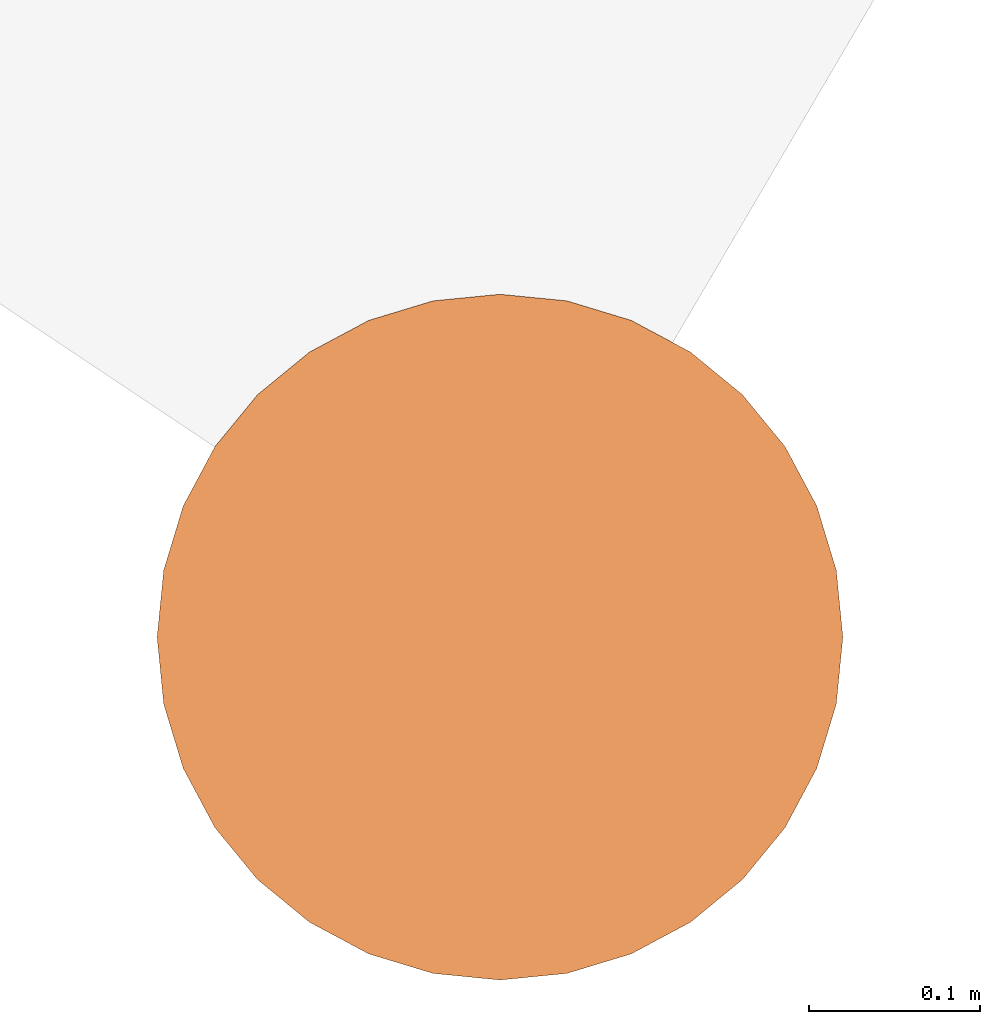
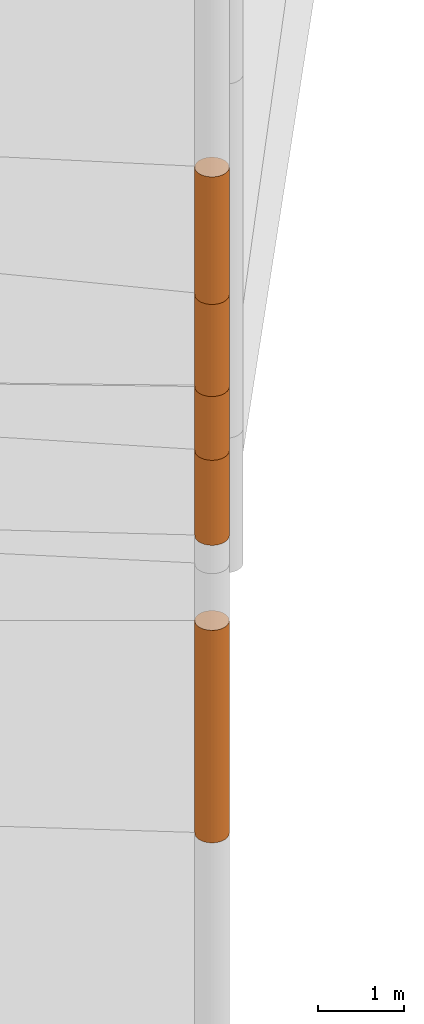
# One storey, part 2 of 24: 5 geographic elements.
"""IFC4 building model written with IfcOpenShell, lengths in metres."""

from ifc_helpers import new_model, entity, si_unit, converted_unit, frame, origin_with_axes, origin_2d_with_axis, place, context, subcontext, project, spatial, polygons, element, save


model = new_model("IFC4")

# Units and contexts
model_context = context("Model", 3, precision=1e-05, world=origin_with_axes())
plan_context = context("Plan", 2, precision=1e-05, world=origin_2d_with_axis())
body_context = subcontext(model_context, "Body", "Model", "MODEL_VIEW")
ifc_project = project(units=[converted_unit("PLANEANGLEUNIT", "degree", entity("IfcReal", 0.0174532925199433), si_unit("PLANEANGLEUNIT", "RADIAN"), dimensions=[0, 0, 0, 0, 0, 0, 0]), si_unit("AREAUNIT", "SQUARE_METRE"), si_unit("VOLUMEUNIT", "CUBIC_METRE"), si_unit("LENGTHUNIT", "METRE")], contexts=[model_context, plan_context])

# Site, building, storey
site_placement = place(None, origin_with_axes())
site = spatial("IfcSite", under=ifc_project, at=site_placement)
building_placement = place(site_placement, origin_with_axes())
building = spatial("IfcBuilding", under=site, at=building_placement, Name="Building")
storey_placement = place(building_placement, origin_with_axes())
storey = spatial("IfcBuildingStorey", under=building, at=storey_placement, Name="Storey")

# Geographic elements
geographic_element_1_placement = place(storey_placement, frame((0.0, 0.0, 1.7000025510788), z_axis=(0.0, 0.0, 1.0), x_axis=(1.0, 0.0, 0.0)))
element("IfcGeographicElement", 1, at=geographic_element_1_placement, inside=storey, PredefinedType="NOTDEFINED", context=body_context, shape_type="Tessellation", body=[
    polygons([(0.0, 0.0, -1.49999988079071), (0.0390180610120296, 0.196157038211823, -1.49999988079071), (0.0, 0.199999988079071, -1.49999988079071), (0.0, 0.0, 1.49999988079071), (0.0, 0.199999988079071, 1.49999988079071), (0.0390180610120296, 0.196157038211823, 1.49999988079071), (0.0765366926789284, 0.18477588891983, -1.49999988079071), (0.0765366926789284, 0.18477588891983, 1.49999988079071), (0.111114047467709, 0.166293919086456, -1.49999988079071), (0.111114047467709, 0.166293919086456, 1.49999988079071), (0.141421362757683, 0.141421362757683, -1.49999988079071), (0.141421362757683, 0.141421362757683, 1.49999988079071), (0.166293919086456, 0.111114047467709, -1.49999988079071), (0.166293919086456, 0.111114047467709, 1.49999988079071), (0.18477588891983, 0.0765366926789284, -1.49999988079071), (0.18477588891983, 0.0765366926789284, 1.49999988079071), (0.196157038211823, 0.0390180610120296, -1.49999988079071), (0.196157038211823, 0.0390180610120296, 1.49999988079071), (0.199999988079071, 0.0, -1.49999988079071), (0.199999988079071, 0.0, 1.49999988079071), (0.196157038211823, -0.0390180610120296, -1.49999988079071), (0.196157038211823, -0.0390180610120296, 1.49999988079071), (0.18477588891983, -0.0765366926789284, -1.49999988079071), (0.18477588891983, -0.0765366926789284, 1.49999988079071), (0.166293919086456, -0.111114047467709, -1.49999988079071), (0.166293919086456, -0.111114047467709, 1.49999988079071), (0.141421362757683, -0.141421362757683, -1.49999988079071), (0.141421362757683, -0.141421362757683, 1.49999988079071), (0.111114047467709, -0.166293919086456, -1.49999988079071), (0.111114047467709, -0.166293919086456, 1.49999988079071), (0.0765366926789284, -0.18477588891983, -1.49999988079071), (0.0765366926789284, -0.18477588891983, 1.49999988079071), (0.0390180610120296, -0.196157038211823, -1.49999988079071), (0.0390180610120296, -0.196157038211823, 1.49999988079071), (0.0, -0.199999988079071, -1.49999988079071), (0.0, -0.199999988079071, 1.49999988079071), (-0.0390180610120296, -0.196157038211823, -1.49999988079071), (-0.0390180610120296, -0.196157038211823, 1.49999988079071), (-0.0765366926789284, -0.18477588891983, -1.49999988079071), (-0.0765366926789284, -0.18477588891983, 1.49999988079071), (-0.111114047467709, -0.166293919086456, -1.49999988079071), (-0.111114047467709, -0.166293919086456, 1.49999988079071), (-0.141421362757683, -0.141421362757683, -1.49999988079071), (-0.141421362757683, -0.141421362757683, 1.49999988079071), (-0.166293919086456, -0.111114047467709, -1.49999988079071), (-0.166293919086456, -0.111114047467709, 1.49999988079071), (-0.18477588891983, -0.0765366926789284, -1.49999988079071), (-0.18477588891983, -0.0765366926789284, 1.49999988079071), (-0.196157038211823, -0.0390180610120296, -1.49999988079071), (-0.196157038211823, -0.0390180610120296, 1.49999988079071), (-0.199999988079071, 0.0, -1.49999988079071), (-0.199999988079071, 0.0, 1.49999988079071), (-0.196157038211823, 0.0390180610120296, -1.49999988079071), (-0.196157038211823, 0.0390180610120296, 1.49999988079071), (-0.18477588891983, 0.0765366926789284, -1.49999988079071), (-0.18477588891983, 0.0765366926789284, 1.49999988079071), (-0.166293919086456, 0.111114047467709, -1.49999988079071), (-0.166293919086456, 0.111114047467709, 1.49999988079071), (-0.141421362757683, 0.141421362757683, -1.49999988079071), (-0.141421362757683, 0.141421362757683, 1.49999988079071), (-0.111114047467709, 0.166293919086456, -1.49999988079071), (-0.111114047467709, 0.166293919086456, 1.49999988079071), (-0.0765366926789284, 0.18477588891983, -1.49999988079071), (-0.0765366926789284, 0.18477588891983, 1.49999988079071), (-0.0390180610120296, 0.196157038211823, -1.49999988079071), (-0.0390180610120296, 0.196157038211823, 1.49999988079071)], [[[3, 2, 1]], [[6, 5, 4]], [[28, 30, 29, 27]], [[2, 7, 1]], [[8, 6, 4]], [[64, 66, 65, 63]], [[7, 9, 1]], [[10, 8, 4]], [[9, 11, 1]], [[12, 10, 4]], [[6, 8, 7, 2]], [[1, 11, 13]], [[12, 4, 14]], [[66, 5, 3, 65]], [[1, 13, 15]], [[14, 4, 16]], [[12, 14, 13, 11]], [[1, 15, 17]], [[16, 4, 18]], [[14, 16, 15, 13]], [[1, 17, 19]], [[4, 20, 18]], [[16, 18, 17, 15]], [[1, 19, 21]], [[4, 22, 20]], [[18, 20, 19, 17]], [[1, 21, 23]], [[22, 4, 24]], [[20, 22, 21, 19]], [[1, 23, 25]], [[4, 26, 24]], [[22, 24, 23, 21]], [[27, 1, 25]], [[4, 28, 26]], [[24, 26, 25, 23]], [[1, 27, 29]], [[28, 4, 30]], [[26, 28, 27, 25]], [[1, 29, 31]], [[4, 32, 30]], [[5, 6, 2, 3]], [[1, 31, 33]], [[4, 34, 32]], [[30, 32, 31, 29]], [[1, 33, 35]], [[4, 36, 34]], [[8, 10, 9, 7]], [[1, 35, 37]], [[4, 38, 36]], [[32, 34, 33, 31]], [[1, 37, 39]], [[4, 40, 38]], [[36, 38, 37, 35]], [[1, 39, 41]], [[4, 42, 40]], [[38, 40, 39, 37]], [[43, 1, 41]], [[4, 44, 42]], [[40, 42, 41, 39]], [[43, 45, 1]], [[46, 44, 4]], [[42, 44, 43, 41]], [[45, 47, 1]], [[4, 48, 46]], [[44, 46, 45, 43]], [[49, 1, 47]], [[4, 50, 48]], [[46, 48, 47, 45]], [[49, 51, 1]], [[52, 50, 4]], [[48, 50, 49, 47]], [[51, 53, 1]], [[54, 52, 4]], [[50, 52, 51, 49]], [[55, 1, 53]], [[4, 56, 54]], [[52, 54, 53, 51]], [[57, 1, 55]], [[58, 56, 4]], [[54, 56, 55, 53]], [[57, 59, 1]], [[60, 58, 4]], [[56, 58, 57, 55]], [[59, 61, 1]], [[62, 60, 4]], [[58, 60, 59, 57]], [[61, 63, 1]], [[64, 62, 4]], [[60, 62, 61, 59]], [[63, 65, 1]], [[66, 64, 4]], [[62, 64, 63, 61]], [[65, 3, 1]], [[5, 66, 4]], [[34, 36, 35, 33]], [[10, 12, 11, 9]]]),
])
geographic_element_2_placement = place(storey_placement, frame((0.0, 0.0, 6.0500020980835), z_axis=(0.0, 0.0, 1.0), x_axis=(1.0, 0.0, 0.0)))
element("IfcGeographicElement", 2, at=geographic_element_2_placement, inside=storey, PredefinedType="NOTDEFINED", context=body_context, shape_type="Tessellation", body=[
    polygons([(0.0, 0.0, -0.449999958276749), (0.0390180610120296, 0.196157038211823, -0.449999958276749), (0.0, 0.199999988079071, -0.449999958276749), (0.0, 0.0, 0.449999958276749), (0.0, 0.199999988079071, 0.449999958276749), (0.0390180610120296, 0.196157038211823, 0.449999958276749), (0.0765366926789284, 0.18477588891983, -0.449999958276749), (0.0765366926789284, 0.18477588891983, 0.449999958276749), (0.111114047467709, 0.166293919086456, -0.449999958276749), (0.111114047467709, 0.166293919086456, 0.449999958276749), (0.141421362757683, 0.141421362757683, -0.449999958276749), (0.141421362757683, 0.141421362757683, 0.449999958276749), (0.166293919086456, 0.111114047467709, -0.449999958276749), (0.166293919086456, 0.111114047467709, 0.449999958276749), (0.18477588891983, 0.0765366926789284, -0.449999958276749), (0.18477588891983, 0.0765366926789284, 0.449999958276749), (0.196157038211823, 0.0390180610120296, -0.449999958276749), (0.196157038211823, 0.0390180610120296, 0.449999958276749), (0.199999988079071, 0.0, -0.449999958276749), (0.199999988079071, 0.0, 0.449999958276749), (0.196157038211823, -0.0390180610120296, -0.449999958276749), (0.196157038211823, -0.0390180610120296, 0.449999958276749), (0.18477588891983, -0.0765366926789284, -0.449999958276749), (0.18477588891983, -0.0765366926789284, 0.449999958276749), (0.166293919086456, -0.111114047467709, -0.449999958276749), (0.166293919086456, -0.111114047467709, 0.449999958276749), (0.141421362757683, -0.141421362757683, -0.449999958276749), (0.141421362757683, -0.141421362757683, 0.449999958276749), (0.111114047467709, -0.166293919086456, -0.449999958276749), (0.111114047467709, -0.166293919086456, 0.449999958276749), (0.0765366926789284, -0.18477588891983, -0.449999958276749), (0.0765366926789284, -0.18477588891983, 0.449999958276749), (0.0390180610120296, -0.196157038211823, -0.449999958276749), (0.0390180610120296, -0.196157038211823, 0.449999958276749), (0.0, -0.199999988079071, -0.449999958276749), (0.0, -0.199999988079071, 0.449999958276749), (-0.0390180610120296, -0.196157038211823, -0.449999958276749), (-0.0390180610120296, -0.196157038211823, 0.449999958276749), (-0.0765366926789284, -0.18477588891983, -0.449999958276749), (-0.0765366926789284, -0.18477588891983, 0.449999958276749), (-0.111114047467709, -0.166293919086456, -0.449999958276749), (-0.111114047467709, -0.166293919086456, 0.449999958276749), (-0.141421362757683, -0.141421362757683, -0.449999958276749), (-0.141421362757683, -0.141421362757683, 0.449999958276749), (-0.166293919086456, -0.111114047467709, -0.449999958276749), (-0.166293919086456, -0.111114047467709, 0.449999958276749), (-0.18477588891983, -0.0765366926789284, -0.449999958276749), (-0.18477588891983, -0.0765366926789284, 0.449999958276749), (-0.196157038211823, -0.0390180610120296, -0.449999958276749), (-0.196157038211823, -0.0390180610120296, 0.449999958276749), (-0.199999988079071, 0.0, -0.449999958276749), (-0.199999988079071, 0.0, 0.449999958276749), (-0.196157038211823, 0.0390180610120296, -0.449999958276749), (-0.196157038211823, 0.0390180610120296, 0.449999958276749), (-0.18477588891983, 0.0765366926789284, -0.449999958276749), (-0.18477588891983, 0.0765366926789284, 0.449999958276749), (-0.166293919086456, 0.111114047467709, -0.449999958276749), (-0.166293919086456, 0.111114047467709, 0.449999958276749), (-0.141421362757683, 0.141421362757683, -0.449999958276749), (-0.141421362757683, 0.141421362757683, 0.449999958276749), (-0.111114047467709, 0.166293919086456, -0.449999958276749), (-0.111114047467709, 0.166293919086456, 0.449999958276749), (-0.0765366926789284, 0.18477588891983, -0.449999958276749), (-0.0765366926789284, 0.18477588891983, 0.449999958276749), (-0.0390180610120296, 0.196157038211823, -0.449999958276749), (-0.0390180610120296, 0.196157038211823, 0.449999958276749)], [[[3, 2, 1]], [[6, 5, 4]], [[32, 34, 33, 31]], [[2, 7, 1]], [[8, 6, 4]], [[64, 66, 65, 63]], [[7, 9, 1]], [[10, 8, 4]], [[9, 11, 1]], [[12, 10, 4]], [[40, 42, 41, 39]], [[1, 11, 13]], [[12, 4, 14]], [[10, 12, 11, 9]], [[1, 13, 15]], [[4, 16, 14]], [[12, 14, 13, 11]], [[1, 15, 17]], [[16, 4, 18]], [[18, 20, 19, 17]], [[1, 17, 19]], [[4, 20, 18]], [[20, 22, 21, 19]], [[1, 19, 21]], [[4, 22, 20]], [[22, 24, 23, 21]], [[1, 21, 23]], [[22, 4, 24]], [[54, 56, 55, 53]], [[1, 23, 25]], [[4, 26, 24]], [[56, 58, 57, 55]], [[1, 25, 27]], [[4, 28, 26]], [[24, 26, 25, 23]], [[1, 27, 29]], [[28, 4, 30]], [[26, 28, 27, 25]], [[1, 29, 31]], [[4, 32, 30]], [[46, 48, 47, 45]], [[1, 31, 33]], [[4, 34, 32]], [[36, 38, 37, 35]], [[1, 33, 35]], [[4, 36, 34]], [[42, 44, 43, 41]], [[1, 35, 37]], [[4, 38, 36]], [[38, 40, 39, 37]], [[1, 37, 39]], [[4, 40, 38]], [[34, 36, 35, 33]], [[1, 39, 41]], [[4, 42, 40]], [[8, 10, 9, 7]], [[43, 1, 41]], [[4, 44, 42]], [[44, 46, 45, 43]], [[43, 45, 1]], [[4, 46, 44]], [[30, 32, 31, 29]], [[45, 47, 1]], [[48, 46, 4]], [[28, 30, 29, 27]], [[49, 1, 47]], [[4, 50, 48]], [[5, 6, 2, 3]], [[49, 51, 1]], [[52, 50, 4]], [[48, 50, 49, 47]], [[51, 53, 1]], [[54, 52, 4]], [[50, 52, 51, 49]], [[55, 1, 53]], [[4, 56, 54]], [[52, 54, 53, 51]], [[55, 57, 1]], [[58, 56, 4]], [[58, 60, 59, 57]], [[59, 1, 57]], [[60, 58, 4]], [[60, 62, 61, 59]], [[59, 61, 1]], [[62, 60, 4]], [[62, 64, 63, 61]], [[61, 63, 1]], [[64, 62, 4]], [[14, 16, 15, 13]], [[63, 65, 1]], [[66, 64, 4]], [[16, 18, 17, 15]], [[65, 3, 1]], [[5, 66, 4]], [[6, 8, 7, 2]], [[66, 5, 3, 65]]]),
])
geographic_element_3_placement = place(storey_placement, frame((0.0, 0.0, 8.70000171661377), z_axis=(0.0, 0.0, 1.0), x_axis=(1.0, 0.0, 0.0)))
element("IfcGeographicElement", 3, at=geographic_element_3_placement, inside=storey, PredefinedType="NOTDEFINED", context=body_context, shape_type="Tessellation", body=[
    polygons([(0.0, 0.0, -0.899999916553497), (0.0390180610120296, 0.196157038211823, -0.899999916553497), (0.0, 0.199999988079071, -0.899999916553497), (0.0, 0.0, 0.899999916553497), (0.0, 0.199999988079071, 0.899999916553497), (0.0390180610120296, 0.196157038211823, 0.899999916553497), (0.0765366926789284, 0.18477588891983, -0.899999916553497), (0.0765366926789284, 0.18477588891983, 0.899999916553497), (0.111114047467709, 0.166293919086456, -0.899999916553497), (0.111114047467709, 0.166293919086456, 0.899999916553497), (0.141421362757683, 0.141421362757683, -0.899999916553497), (0.141421362757683, 0.141421362757683, 0.899999916553497), (0.166293919086456, 0.111114047467709, -0.899999916553497), (0.166293919086456, 0.111114047467709, 0.899999916553497), (0.18477588891983, 0.0765366926789284, -0.899999916553497), (0.18477588891983, 0.0765366926789284, 0.899999916553497), (0.196157038211823, 0.0390180610120296, -0.899999916553497), (0.196157038211823, 0.0390180610120296, 0.899999916553497), (0.199999988079071, 0.0, -0.899999916553497), (0.199999988079071, 0.0, 0.899999916553497), (0.196157038211823, -0.0390180610120296, -0.899999916553497), (0.196157038211823, -0.0390180610120296, 0.899999916553497), (0.18477588891983, -0.0765366926789284, -0.899999916553497), (0.18477588891983, -0.0765366926789284, 0.899999916553497), (0.166293919086456, -0.111114047467709, -0.899999916553497), (0.166293919086456, -0.111114047467709, 0.899999916553497), (0.141421362757683, -0.141421362757683, -0.899999916553497), (0.141421362757683, -0.141421362757683, 0.899999916553497), (0.111114047467709, -0.166293919086456, -0.899999916553497), (0.111114047467709, -0.166293919086456, 0.899999916553497), (0.0765366926789284, -0.18477588891983, -0.899999916553497), (0.0765366926789284, -0.18477588891983, 0.899999916553497), (0.0390180610120296, -0.196157038211823, -0.899999916553497), (0.0390180610120296, -0.196157038211823, 0.899999916553497), (0.0, -0.199999988079071, -0.899999916553497), (0.0, -0.199999988079071, 0.899999916553497), (-0.0390180610120296, -0.196157038211823, -0.899999916553497), (-0.0390180610120296, -0.196157038211823, 0.899999916553497), (-0.0765366926789284, -0.18477588891983, -0.899999916553497), (-0.0765366926789284, -0.18477588891983, 0.899999916553497), (-0.111114047467709, -0.166293919086456, -0.899999916553497), (-0.111114047467709, -0.166293919086456, 0.899999916553497), (-0.141421362757683, -0.141421362757683, -0.899999916553497), (-0.141421362757683, -0.141421362757683, 0.899999916553497), (-0.166293919086456, -0.111114047467709, -0.899999916553497), (-0.166293919086456, -0.111114047467709, 0.899999916553497), (-0.18477588891983, -0.0765366926789284, -0.899999916553497), (-0.18477588891983, -0.0765366926789284, 0.899999916553497), (-0.196157038211823, -0.0390180610120296, -0.899999916553497), (-0.196157038211823, -0.0390180610120296, 0.899999916553497), (-0.199999988079071, 0.0, -0.899999916553497), (-0.199999988079071, 0.0, 0.899999916553497), (-0.196157038211823, 0.0390180610120296, -0.899999916553497), (-0.196157038211823, 0.0390180610120296, 0.899999916553497), (-0.18477588891983, 0.0765366926789284, -0.899999916553497), (-0.18477588891983, 0.0765366926789284, 0.899999916553497), (-0.166293919086456, 0.111114047467709, -0.899999916553497), (-0.166293919086456, 0.111114047467709, 0.899999916553497), (-0.141421362757683, 0.141421362757683, -0.899999916553497), (-0.141421362757683, 0.141421362757683, 0.899999916553497), (-0.111114047467709, 0.166293919086456, -0.899999916553497), (-0.111114047467709, 0.166293919086456, 0.899999916553497), (-0.0765366926789284, 0.18477588891983, -0.899999916553497), (-0.0765366926789284, 0.18477588891983, 0.899999916553497), (-0.0390180610120296, 0.196157038211823, -0.899999916553497), (-0.0390180610120296, 0.196157038211823, 0.899999916553497)], [[[3, 2, 1]], [[6, 5, 4]], [[32, 34, 33, 31]], [[2, 7, 1]], [[8, 6, 4]], [[64, 66, 65, 63]], [[7, 9, 1]], [[10, 8, 4]], [[9, 11, 1]], [[12, 10, 4]], [[40, 42, 41, 39]], [[1, 11, 13]], [[12, 4, 14]], [[10, 12, 11, 9]], [[1, 13, 15]], [[4, 16, 14]], [[12, 14, 13, 11]], [[1, 15, 17]], [[16, 4, 18]], [[18, 20, 19, 17]], [[1, 17, 19]], [[4, 20, 18]], [[20, 22, 21, 19]], [[1, 19, 21]], [[4, 22, 20]], [[22, 24, 23, 21]], [[1, 21, 23]], [[22, 4, 24]], [[54, 56, 55, 53]], [[1, 23, 25]], [[4, 26, 24]], [[56, 58, 57, 55]], [[1, 25, 27]], [[4, 28, 26]], [[24, 26, 25, 23]], [[1, 27, 29]], [[28, 4, 30]], [[26, 28, 27, 25]], [[1, 29, 31]], [[4, 32, 30]], [[46, 48, 47, 45]], [[1, 31, 33]], [[4, 34, 32]], [[36, 38, 37, 35]], [[1, 33, 35]], [[4, 36, 34]], [[42, 44, 43, 41]], [[1, 35, 37]], [[4, 38, 36]], [[38, 40, 39, 37]], [[1, 37, 39]], [[4, 40, 38]], [[34, 36, 35, 33]], [[1, 39, 41]], [[4, 42, 40]], [[8, 10, 9, 7]], [[43, 1, 41]], [[4, 44, 42]], [[44, 46, 45, 43]], [[43, 45, 1]], [[4, 46, 44]], [[30, 32, 31, 29]], [[45, 47, 1]], [[48, 46, 4]], [[28, 30, 29, 27]], [[49, 1, 47]], [[4, 50, 48]], [[5, 6, 2, 3]], [[49, 51, 1]], [[52, 50, 4]], [[48, 50, 49, 47]], [[51, 53, 1]], [[54, 52, 4]], [[50, 52, 51, 49]], [[55, 1, 53]], [[4, 56, 54]], [[52, 54, 53, 51]], [[55, 57, 1]], [[58, 56, 4]], [[58, 60, 59, 57]], [[59, 1, 57]], [[60, 58, 4]], [[60, 62, 61, 59]], [[59, 61, 1]], [[62, 60, 4]], [[62, 64, 63, 61]], [[61, 63, 1]], [[64, 62, 4]], [[14, 16, 15, 13]], [[63, 65, 1]], [[66, 64, 4]], [[16, 18, 17, 15]], [[65, 3, 1]], [[5, 66, 4]], [[6, 8, 7, 2]], [[66, 5, 3, 65]]]),
])
geographic_element_4_placement = place(storey_placement, frame((0.0, 0.0, 5.00000238418579), z_axis=(0.0, 0.0, 1.0), x_axis=(1.0, 0.0, 0.0)))
element("IfcGeographicElement", 4, at=geographic_element_4_placement, inside=storey, PredefinedType="NOTDEFINED", context=body_context, shape_type="Tessellation", body=[
    polygons([(0.0, 0.0, -0.600000023841858), (0.0390180610120296, 0.196157038211823, -0.600000023841858), (0.0, 0.199999988079071, -0.600000023841858), (0.0, 0.0, 0.600000023841858), (0.0, 0.199999988079071, 0.600000023841858), (0.0390180610120296, 0.196157038211823, 0.600000023841858), (0.0765366926789284, 0.18477588891983, -0.600000023841858), (0.0765366926789284, 0.18477588891983, 0.600000023841858), (0.111114047467709, 0.166293919086456, -0.600000023841858), (0.111114047467709, 0.166293919086456, 0.600000023841858), (0.141421362757683, 0.141421362757683, -0.600000023841858), (0.141421362757683, 0.141421362757683, 0.600000023841858), (0.166293919086456, 0.111114047467709, -0.600000023841858), (0.166293919086456, 0.111114047467709, 0.600000023841858), (0.18477588891983, 0.0765366926789284, -0.600000023841858), (0.18477588891983, 0.0765366926789284, 0.600000023841858), (0.196157038211823, 0.0390180610120296, -0.600000023841858), (0.196157038211823, 0.0390180610120296, 0.600000023841858), (0.199999988079071, 0.0, -0.600000023841858), (0.199999988079071, 0.0, 0.600000023841858), (0.196157038211823, -0.0390180610120296, -0.600000023841858), (0.196157038211823, -0.0390180610120296, 0.600000023841858), (0.18477588891983, -0.0765366926789284, -0.600000023841858), (0.18477588891983, -0.0765366926789284, 0.600000023841858), (0.166293919086456, -0.111114047467709, -0.600000023841858), (0.166293919086456, -0.111114047467709, 0.600000023841858), (0.141421362757683, -0.141421362757683, -0.600000023841858), (0.141421362757683, -0.141421362757683, 0.600000023841858), (0.111114047467709, -0.166293919086456, -0.600000023841858), (0.111114047467709, -0.166293919086456, 0.600000023841858), (0.0765366926789284, -0.18477588891983, -0.600000023841858), (0.0765366926789284, -0.18477588891983, 0.600000023841858), (0.0390180610120296, -0.196157038211823, -0.600000023841858), (0.0390180610120296, -0.196157038211823, 0.600000023841858), (0.0, -0.199999988079071, -0.600000023841858), (0.0, -0.199999988079071, 0.600000023841858), (-0.0390180610120296, -0.196157038211823, -0.600000023841858), (-0.0390180610120296, -0.196157038211823, 0.600000023841858), (-0.0765366926789284, -0.18477588891983, -0.600000023841858), (-0.0765366926789284, -0.18477588891983, 0.600000023841858), (-0.111114047467709, -0.166293919086456, -0.600000023841858), (-0.111114047467709, -0.166293919086456, 0.600000023841858), (-0.141421362757683, -0.141421362757683, -0.600000023841858), (-0.141421362757683, -0.141421362757683, 0.600000023841858), (-0.166293919086456, -0.111114047467709, -0.600000023841858), (-0.166293919086456, -0.111114047467709, 0.600000023841858), (-0.18477588891983, -0.0765366926789284, -0.600000023841858), (-0.18477588891983, -0.0765366926789284, 0.600000023841858), (-0.196157038211823, -0.0390180610120296, -0.600000023841858), (-0.196157038211823, -0.0390180610120296, 0.600000023841858), (-0.199999988079071, 0.0, -0.600000023841858), (-0.199999988079071, 0.0, 0.600000023841858), (-0.196157038211823, 0.0390180610120296, -0.600000023841858), (-0.196157038211823, 0.0390180610120296, 0.600000023841858), (-0.18477588891983, 0.0765366926789284, -0.600000023841858), (-0.18477588891983, 0.0765366926789284, 0.600000023841858), (-0.166293919086456, 0.111114047467709, -0.600000023841858), (-0.166293919086456, 0.111114047467709, 0.600000023841858), (-0.141421362757683, 0.141421362757683, -0.600000023841858), (-0.141421362757683, 0.141421362757683, 0.600000023841858), (-0.111114047467709, 0.166293919086456, -0.600000023841858), (-0.111114047467709, 0.166293919086456, 0.600000023841858), (-0.0765366926789284, 0.18477588891983, -0.600000023841858), (-0.0765366926789284, 0.18477588891983, 0.600000023841858), (-0.0390180610120296, 0.196157038211823, -0.600000023841858), (-0.0390180610120296, 0.196157038211823, 0.600000023841858)], [[[3, 2, 1]], [[6, 5, 4]], [[28, 30, 29, 27]], [[2, 7, 1]], [[8, 6, 4]], [[36, 38, 37, 35]], [[7, 9, 1]], [[10, 8, 4]], [[56, 58, 57, 55]], [[9, 11, 1]], [[12, 10, 4]], [[58, 60, 59, 57]], [[11, 13, 1]], [[12, 4, 14]], [[54, 56, 55, 53]], [[1, 13, 15]], [[14, 4, 16]], [[10, 12, 11, 9]], [[1, 15, 17]], [[16, 4, 18]], [[60, 62, 61, 59]], [[1, 17, 19]], [[18, 4, 20]], [[16, 18, 17, 15]], [[1, 19, 21]], [[20, 4, 22]], [[18, 20, 19, 17]], [[1, 21, 23]], [[22, 4, 24]], [[20, 22, 21, 19]], [[1, 23, 25]], [[24, 4, 26]], [[22, 24, 23, 21]], [[27, 1, 25]], [[26, 4, 28]], [[24, 26, 25, 23]], [[1, 27, 29]], [[28, 4, 30]], [[62, 64, 63, 61]], [[1, 29, 31]], [[4, 32, 30]], [[64, 66, 65, 63]], [[1, 31, 33]], [[4, 34, 32]], [[30, 32, 31, 29]], [[1, 33, 35]], [[4, 36, 34]], [[8, 10, 9, 7]], [[1, 35, 37]], [[4, 38, 36]], [[32, 34, 33, 31]], [[1, 37, 39]], [[4, 40, 38]], [[6, 8, 7, 2]], [[1, 39, 41]], [[4, 42, 40]], [[38, 40, 39, 37]], [[43, 1, 41]], [[4, 44, 42]], [[40, 42, 41, 39]], [[45, 1, 43]], [[46, 44, 4]], [[42, 44, 43, 41]], [[47, 1, 45]], [[4, 48, 46]], [[44, 46, 45, 43]], [[49, 1, 47]], [[4, 50, 48]], [[46, 48, 47, 45]], [[51, 1, 49]], [[4, 52, 50]], [[48, 50, 49, 47]], [[53, 1, 51]], [[4, 54, 52]], [[66, 5, 3, 65]], [[55, 1, 53]], [[4, 56, 54]], [[52, 54, 53, 51]], [[57, 1, 55]], [[4, 58, 56]], [[57, 59, 1]], [[60, 58, 4]], [[34, 36, 35, 33]], [[59, 61, 1]], [[62, 60, 4]], [[14, 16, 15, 13]], [[61, 63, 1]], [[64, 62, 4]], [[26, 28, 27, 25]], [[63, 65, 1]], [[66, 64, 4]], [[5, 6, 2, 3]], [[65, 3, 1]], [[5, 66, 4]], [[50, 52, 51, 49]], [[12, 14, 13, 11]]]),
])
geographic_element_5_placement = place(storey_placement, frame((0.0, 0.0, 7.15000200271606), z_axis=(0.0, 0.0, 1.0), x_axis=(1.0, 0.0, 0.0)))
element("IfcGeographicElement", 5, at=geographic_element_5_placement, inside=storey, PredefinedType="NOTDEFINED", context=body_context, shape_type="Tessellation", body=[
    polygons([(0.0, 0.0, -0.649999916553497), (0.0390180610120296, 0.196157038211823, -0.649999916553497), (0.0, 0.199999988079071, -0.649999916553497), (0.0, 0.0, 0.649999916553497), (0.0, 0.199999988079071, 0.649999916553497), (0.0390180610120296, 0.196157038211823, 0.649999916553497), (0.0765366926789284, 0.18477588891983, -0.649999916553497), (0.0765366926789284, 0.18477588891983, 0.649999916553497), (0.111114047467709, 0.166293919086456, -0.649999916553497), (0.111114047467709, 0.166293919086456, 0.649999916553497), (0.141421362757683, 0.141421362757683, -0.649999916553497), (0.141421362757683, 0.141421362757683, 0.649999916553497), (0.166293919086456, 0.111114047467709, -0.649999916553497), (0.166293919086456, 0.111114047467709, 0.649999916553497), (0.18477588891983, 0.0765366926789284, -0.649999916553497), (0.18477588891983, 0.0765366926789284, 0.649999916553497), (0.196157038211823, 0.0390180610120296, -0.649999916553497), (0.196157038211823, 0.0390180610120296, 0.649999916553497), (0.199999988079071, 0.0, -0.649999916553497), (0.199999988079071, 0.0, 0.649999916553497), (0.196157038211823, -0.0390180610120296, -0.649999916553497), (0.196157038211823, -0.0390180610120296, 0.649999916553497), (0.18477588891983, -0.0765366926789284, -0.649999916553497), (0.18477588891983, -0.0765366926789284, 0.649999916553497), (0.166293919086456, -0.111114047467709, -0.649999916553497), (0.166293919086456, -0.111114047467709, 0.649999916553497), (0.141421362757683, -0.141421362757683, -0.649999916553497), (0.141421362757683, -0.141421362757683, 0.649999916553497), (0.111114047467709, -0.166293919086456, -0.649999916553497), (0.111114047467709, -0.166293919086456, 0.649999916553497), (0.0765366926789284, -0.18477588891983, -0.649999916553497), (0.0765366926789284, -0.18477588891983, 0.649999916553497), (0.0390180610120296, -0.196157038211823, -0.649999916553497), (0.0390180610120296, -0.196157038211823, 0.649999916553497), (0.0, -0.199999988079071, -0.649999916553497), (0.0, -0.199999988079071, 0.649999916553497), (-0.0390180610120296, -0.196157038211823, -0.649999916553497), (-0.0390180610120296, -0.196157038211823, 0.649999916553497), (-0.0765366926789284, -0.18477588891983, -0.649999916553497), (-0.0765366926789284, -0.18477588891983, 0.649999916553497), (-0.111114047467709, -0.166293919086456, -0.649999916553497), (-0.111114047467709, -0.166293919086456, 0.649999916553497), (-0.141421362757683, -0.141421362757683, -0.649999916553497), (-0.141421362757683, -0.141421362757683, 0.649999916553497), (-0.166293919086456, -0.111114047467709, -0.649999916553497), (-0.166293919086456, -0.111114047467709, 0.649999916553497), (-0.18477588891983, -0.0765366926789284, -0.649999916553497), (-0.18477588891983, -0.0765366926789284, 0.649999916553497), (-0.196157038211823, -0.0390180610120296, -0.649999916553497), (-0.196157038211823, -0.0390180610120296, 0.649999916553497), (-0.199999988079071, 0.0, -0.649999916553497), (-0.199999988079071, 0.0, 0.649999916553497), (-0.196157038211823, 0.0390180610120296, -0.649999916553497), (-0.196157038211823, 0.0390180610120296, 0.649999916553497), (-0.18477588891983, 0.0765366926789284, -0.649999916553497), (-0.18477588891983, 0.0765366926789284, 0.649999916553497), (-0.166293919086456, 0.111114047467709, -0.649999916553497), (-0.166293919086456, 0.111114047467709, 0.649999916553497), (-0.141421362757683, 0.141421362757683, -0.649999916553497), (-0.141421362757683, 0.141421362757683, 0.649999916553497), (-0.111114047467709, 0.166293919086456, -0.649999916553497), (-0.111114047467709, 0.166293919086456, 0.649999916553497), (-0.0765366926789284, 0.18477588891983, -0.649999916553497), (-0.0765366926789284, 0.18477588891983, 0.649999916553497), (-0.0390180610120296, 0.196157038211823, -0.649999916553497), (-0.0390180610120296, 0.196157038211823, 0.649999916553497)], [[[3, 2, 1]], [[6, 5, 4]], [[32, 34, 33, 31]], [[2, 7, 1]], [[8, 6, 4]], [[64, 66, 65, 63]], [[7, 9, 1]], [[10, 8, 4]], [[9, 11, 1]], [[12, 10, 4]], [[40, 42, 41, 39]], [[1, 11, 13]], [[12, 4, 14]], [[10, 12, 11, 9]], [[1, 13, 15]], [[4, 16, 14]], [[12, 14, 13, 11]], [[1, 15, 17]], [[4, 18, 16]], [[18, 20, 19, 17]], [[1, 17, 19]], [[4, 20, 18]], [[20, 22, 21, 19]], [[1, 19, 21]], [[4, 22, 20]], [[22, 24, 23, 21]], [[1, 21, 23]], [[22, 4, 24]], [[54, 56, 55, 53]], [[1, 23, 25]], [[24, 4, 26]], [[56, 58, 57, 55]], [[1, 25, 27]], [[4, 28, 26]], [[24, 26, 25, 23]], [[1, 27, 29]], [[28, 4, 30]], [[26, 28, 27, 25]], [[1, 29, 31]], [[4, 32, 30]], [[46, 48, 47, 45]], [[1, 31, 33]], [[4, 34, 32]], [[36, 38, 37, 35]], [[1, 33, 35]], [[4, 36, 34]], [[42, 44, 43, 41]], [[1, 35, 37]], [[4, 38, 36]], [[38, 40, 39, 37]], [[1, 37, 39]], [[4, 40, 38]], [[34, 36, 35, 33]], [[1, 39, 41]], [[4, 42, 40]], [[8, 10, 9, 7]], [[43, 1, 41]], [[4, 44, 42]], [[44, 46, 45, 43]], [[43, 45, 1]], [[4, 46, 44]], [[30, 32, 31, 29]], [[47, 1, 45]], [[48, 46, 4]], [[28, 30, 29, 27]], [[49, 1, 47]], [[50, 48, 4]], [[5, 6, 2, 3]], [[49, 51, 1]], [[52, 50, 4]], [[48, 50, 49, 47]], [[51, 53, 1]], [[54, 52, 4]], [[50, 52, 51, 49]], [[53, 55, 1]], [[4, 56, 54]], [[52, 54, 53, 51]], [[55, 57, 1]], [[4, 58, 56]], [[58, 60, 59, 57]], [[59, 1, 57]], [[60, 58, 4]], [[60, 62, 61, 59]], [[59, 61, 1]], [[62, 60, 4]], [[62, 64, 63, 61]], [[61, 63, 1]], [[64, 62, 4]], [[14, 16, 15, 13]], [[63, 65, 1]], [[66, 64, 4]], [[16, 18, 17, 15]], [[65, 3, 1]], [[5, 66, 4]], [[6, 8, 7, 2]], [[66, 5, 3, 65]]]),
])

save(model, "model.ifc")
